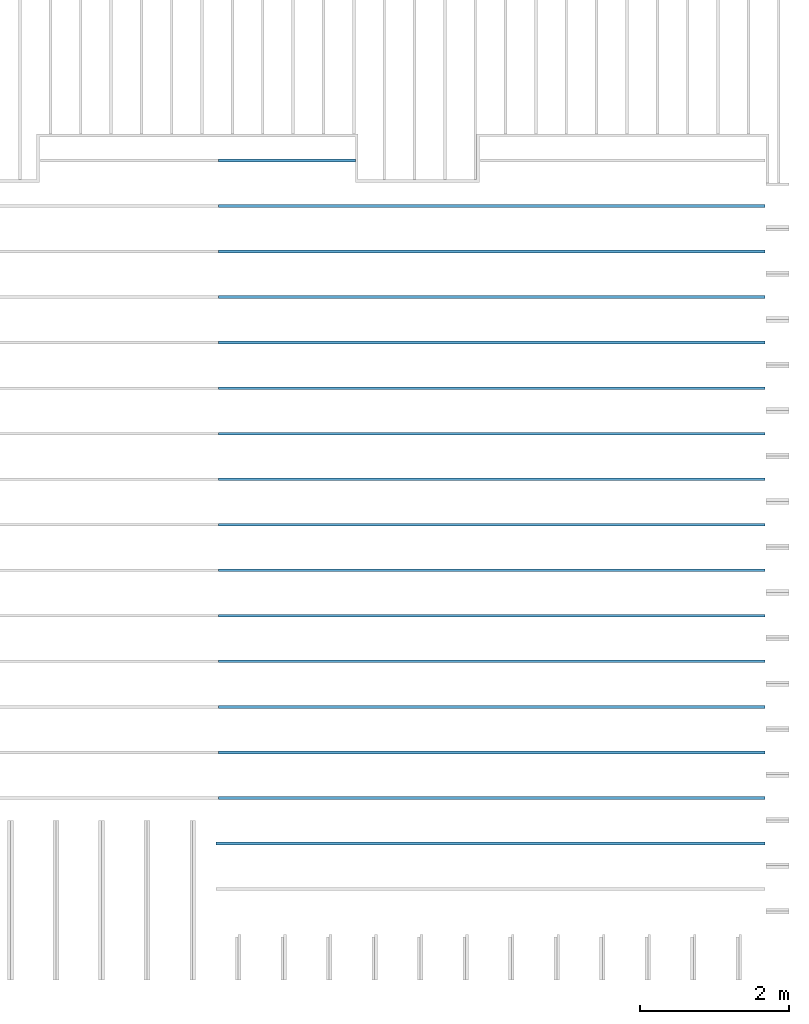
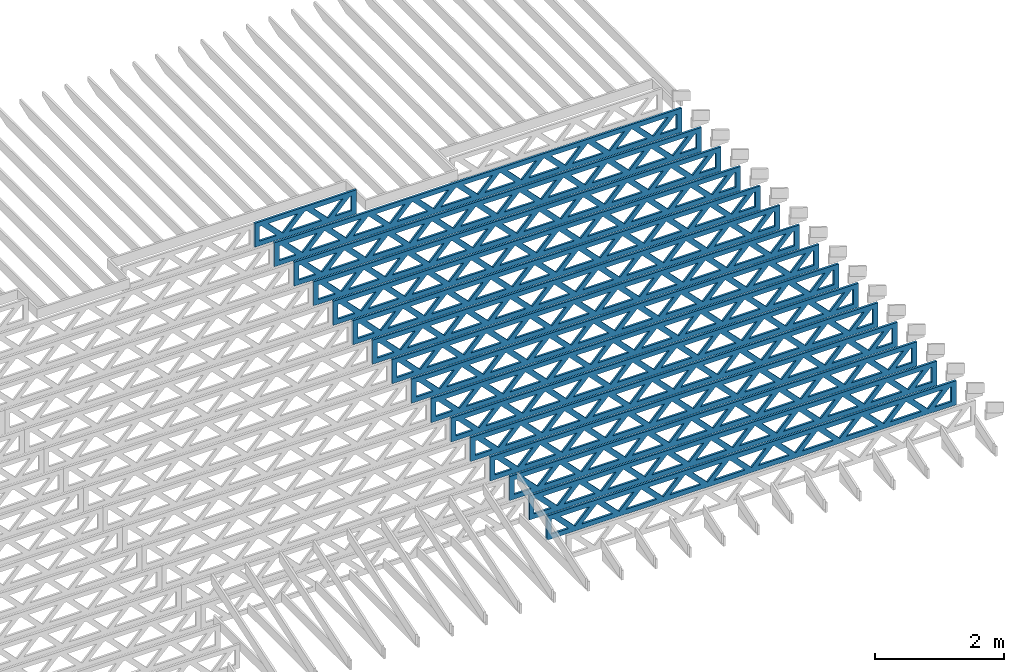
# One storey, part 12 of 18: 16 beams, 1 element without a shape of its own.
"""IFC4 building model written with IfcOpenShell, lengths in feet."""

from ifc_helpers import new_model, entity, si_unit, converted_unit, derived_unit, direction, frame, frame_2d, origin, origin_2d_with_axis, place, context, subcontext, project, spatial, rectangle, extrude, source, transform, mapped, material, material_profile, profile_set, profile_usage, type_object, type_shapes, element, aggregate, save


model = new_model("IFC4")

# Units and contexts
model_context_1 = context("Model", 3, precision=0.0001, world=origin(), true_north=direction((6.12303176911189e-17, 1.0)))
model_context_2 = context("Model", 3, precision=0.0001, world=origin(), true_north=direction((6.12303176911189e-17, 1.0)))
body_context = subcontext(model_context_2, "Body", "Model", "MODEL_VIEW")
ifc_project = project(units=[converted_unit("LENGTHUNIT", "FOOT", entity("IfcRatioMeasure", 0.3048), si_unit("LENGTHUNIT", "METRE"), dimensions=[1, 0, 0, 0, 0, 0, 0]), converted_unit("AREAUNIT", "SQUARE FOOT", entity("IfcRatioMeasure", 0.09290304), si_unit("AREAUNIT", "SQUARE_METRE"), dimensions=[2, 0, 0, 0, 0, 0, 0]), converted_unit("VOLUMEUNIT", "CUBIC FOOT", entity("IfcRatioMeasure", 0.028316846592), si_unit("VOLUMEUNIT", "CUBIC_METRE"), dimensions=[3, 0, 0, 0, 0, 0, 0]), converted_unit("PLANEANGLEUNIT", "DEGREE", entity("IfcRatioMeasure", 0.0174532925199433), si_unit("PLANEANGLEUNIT", "RADIAN"), dimensions=[0, 0, 0, 0, 0, 0, 0]), si_unit("MASSUNIT", "GRAM", prefix="KILO"), derived_unit("MASSDENSITYUNIT", [(si_unit("MASSUNIT", "GRAM", prefix="KILO"), 1), (si_unit("LENGTHUNIT", "METRE"), -3)]), derived_unit("MOMENTOFINERTIAUNIT", [(si_unit("LENGTHUNIT", "METRE"), 4)]), si_unit("TIMEUNIT", "SECOND"), si_unit("FREQUENCYUNIT", "HERTZ"), si_unit("THERMODYNAMICTEMPERATUREUNIT", "DEGREE_CELSIUS"), derived_unit("THERMALTRANSMITTANCEUNIT", [(si_unit("MASSUNIT", "GRAM", prefix="KILO"), 1), (si_unit("THERMODYNAMICTEMPERATUREUNIT", "KELVIN"), -1), (si_unit("TIMEUNIT", "SECOND"), -3)]), derived_unit("VOLUMETRICFLOWRATEUNIT", [(si_unit("LENGTHUNIT", "METRE"), 3), (si_unit("TIMEUNIT", "SECOND"), -1)]), si_unit("ELECTRICCURRENTUNIT", "AMPERE"), si_unit("ELECTRICVOLTAGEUNIT", "VOLT"), si_unit("POWERUNIT", "WATT"), si_unit("FORCEUNIT", "NEWTON"), si_unit("ILLUMINANCEUNIT", "LUX"), si_unit("LUMINOUSFLUXUNIT", "LUMEN"), si_unit("LUMINOUSINTENSITYUNIT", "CANDELA"), derived_unit("USERDEFINED", [(si_unit("MASSUNIT", "GRAM", prefix="KILO"), -1), (si_unit("LENGTHUNIT", "METRE"), -2), (si_unit("TIMEUNIT", "SECOND"), 3), (si_unit("LUMINOUSFLUXUNIT", "LUMEN"), 1)]), derived_unit("LINEARVELOCITYUNIT", [(si_unit("LENGTHUNIT", "METRE"), 1), (si_unit("TIMEUNIT", "SECOND"), -1)]), si_unit("PRESSUREUNIT", "PASCAL"), derived_unit("USERDEFINED", [(si_unit("LENGTHUNIT", "METRE"), -2), (si_unit("MASSUNIT", "GRAM", prefix="KILO"), 1), (si_unit("TIMEUNIT", "SECOND"), -2)]), derived_unit("LINEARFORCEUNIT", [(si_unit("MASSUNIT", "GRAM", prefix="KILO"), 1), (si_unit("LENGTHUNIT", "METRE"), 1), (si_unit("TIMEUNIT", "SECOND"), -2), (si_unit("LENGTHUNIT", "METRE"), -1)]), derived_unit("PLANARFORCEUNIT", [(si_unit("MASSUNIT", "GRAM", prefix="KILO"), 1), (si_unit("LENGTHUNIT", "METRE"), 1), (si_unit("TIMEUNIT", "SECOND"), -2), (si_unit("LENGTHUNIT", "METRE"), -2)])], contexts=[model_context_1])

# Site, building, storey
site_placement = place(None, origin())
site = spatial("IfcSite", under=ifc_project, at=site_placement, CompositionType="ELEMENT")
building_placement = place(site_placement, origin())
building = spatial("IfcBuilding", under=site, at=building_placement, CompositionType="ELEMENT")
storey_placement = place(building_placement, frame((0.0, 0.0, 30.4375000000082)))
storey = spatial("IfcBuildingStorey", under=building, at=storey_placement, Name="ROOF", CompositionType="ELEMENT", Elevation=30.4375000000082)

# Assembly, beams
assembly_placement = place(storey_placement, origin())
assembly = element("IfcElementAssembly", 1, at=assembly_placement, inside=storey, Name="Structural Beam System:Structural Framing System", ObjectType="Structural Beam System:Structural Framing System", AssemblyPlace="NOTDEFINED", PredefinedType="BEAM_GRID")
ifc_material = material(Name="WOOD TRUSS", Category="Materials")
ifc_material_profile_1 = material_profile(ifc_material, rectangle(XDim=1.73473973950632, YDim=0.125, at=origin_2d_with_axis()))
ifc_material_profile_2 = material_profile(ifc_material, rectangle(XDim=1.73473973950633, YDim=0.125, at=frame_2d((-1.11022302462516e-16, 0.0), x_axis=(1.0, 0.0))))
ifc_material_profile_3 = material_profile(ifc_material, rectangle(XDim=1.73473973950632, YDim=0.125, at=origin_2d_with_axis()))
ifc_material_profile_4 = material_profile(ifc_material, rectangle(XDim=1.73473973950633, YDim=0.125, at=origin_2d_with_axis()))
ifc_material_profile_5 = material_profile(ifc_material, rectangle(XDim=1.73473973950632, YDim=0.125, at=frame_2d((-5.55111512312578e-17, 0.0), x_axis=(1.0, 0.0))))
ifc_material_profile_6 = material_profile(ifc_material, rectangle(XDim=1.73473973950633, YDim=0.125, at=frame_2d((-2.77555756156289e-16, 0.0), x_axis=(1.0, 0.0))))
ifc_material_profile_7 = material_profile(ifc_material, rectangle(XDim=1.73473973950632, YDim=0.125, at=frame_2d((-4.9960036108132e-16, 0.0), x_axis=(1.0, 0.0))))
ifc_material_profile_8 = material_profile(ifc_material, rectangle(XDim=1.73473973950633, YDim=0.125, at=frame_2d((4.44089209850063e-16, 0.0), x_axis=(1.0, 0.0))))
ifc_material_profile_9 = material_profile(ifc_material, rectangle(XDim=1.73473973950632, YDim=0.125, at=origin_2d_with_axis()))
ifc_material_profile_10 = material_profile(ifc_material, rectangle(XDim=1.73473973950633, YDim=0.125, at=frame_2d((-4.9960036108132e-16, 0.0), x_axis=(1.0, 0.0))))
ifc_material_profile_11 = material_profile(ifc_material, rectangle(XDim=0.291666666666664, YDim=0.125, at=frame_2d((-2.77555756156289e-17, 0.0), x_axis=(1.0, 0.0))))
ifc_material_profile_12 = material_profile(ifc_material, rectangle(XDim=0.291666666666628, YDim=0.124999999999995, at=frame_2d((-5.55111512312578e-17, 0.0), x_axis=(1.0, 0.0))))
ifc_material_profile_13 = material_profile(ifc_material, rectangle(XDim=0.916666666666666, YDim=0.125000000000003, at=frame_2d((-2.77555756156289e-17, 0.0), x_axis=(1.0, 0.0))))
ifc_material_profile_14 = material_profile(ifc_material, rectangle(XDim=0.916666666666651, YDim=0.125, at=frame_2d((-2.77555756156289e-17, 0.0), x_axis=(1.0, 0.0))))
ifc_profile_set = profile_set([ifc_material_profile_1, ifc_material_profile_2, ifc_material_profile_3, ifc_material_profile_4, ifc_material_profile_5, ifc_material_profile_6, ifc_material_profile_7, ifc_material_profile_8, ifc_material_profile_9, ifc_material_profile_10, ifc_material_profile_11, ifc_material_profile_12, ifc_material_profile_13, ifc_material_profile_14])
ifc_profile_usage_1 = profile_usage(ifc_profile_set, cardinal=8)
beam_type_1 = type_object("IfcBeamType", PredefinedType="BEAM", material=ifc_profile_set)
shared_shape_1 = source(origin(), body_context, "Body", "SweptSolid", [
    extrude(rectangle(XDim=1.73473973950632, YDim=0.125, at=frame_2d((8.88178419700125e-16, 0.0), x_axis=(1.0, 0.0))), frame((8.31693784968716, 0.0, 0.101118361020562), z_axis=(0.720569184836762, 0.0, -0.693383046997606), x_axis=(0.693383046997606, 0.0, 0.720569184836762)), (0.0, 0.0, 1.0), 0.291666666666667),
    extrude(rectangle(XDim=1.73473973950633, YDim=0.125, at=frame_2d((4.9960036108132e-16, 0.0), x_axis=(1.0, 0.0))), frame((7.06665197601389, 0.0, -0.101118361020407), z_axis=(0.720569184836758, 0.0, 0.69338304699761), x_axis=(0.69338304699761, 0.0, -0.720569184836758)), (0.0, 0.0, 1.0), 0.291666666666667),
    extrude(rectangle(XDim=1.73473973950632, YDim=0.125, at=origin_2d_with_axis()), frame((5.71797854336309, 0.0, 0.101118361020562), z_axis=(0.720569184836762, 0.0, -0.693383046997606), x_axis=(0.693383046997606, 0.0, 0.720569184836762)), (0.0, 0.0, 1.0), 0.291666666666667),
    extrude(rectangle(XDim=1.73473973950633, YDim=0.125, at=frame_2d((-4.9960036108132e-16, 0.0), x_axis=(1.0, 0.0))), frame((4.46769266968982, 0.0, -0.101118361020407), z_axis=(0.720569184836758, 0.0, 0.69338304699761), x_axis=(0.69338304699761, 0.0, -0.720569184836758)), (0.0, 0.0, 1.0), 0.291666666666667),
    extrude(rectangle(XDim=1.73473973950632, YDim=0.125, at=frame_2d((3.33066907387547e-16, 0.0), x_axis=(1.0, 0.0))), frame((3.11901923703901, 0.0, 0.101118361020562), z_axis=(0.720569184836762, 0.0, -0.693383046997606), x_axis=(0.693383046997606, 0.0, 0.720569184836762)), (0.0, 0.0, 1.0), 0.291666666666667),
    extrude(rectangle(XDim=1.73473973950633, YDim=0.125, at=frame_2d((-1.11022302462516e-16, 0.0), x_axis=(1.0, 0.0))), frame((1.86873336336574, 0.0, -0.101118361020407), z_axis=(0.720569184836758, 0.0, 0.69338304699761), x_axis=(0.69338304699761, 0.0, -0.720569184836758)), (0.0, 0.0, 1.0), 0.291666666666666),
    extrude(rectangle(XDim=1.73473973950632, YDim=0.125, at=frame_2d((5.55111512312578e-17, 0.0), x_axis=(1.0, 0.0))), frame((0.520059930714937, 0.0, 0.101118361020562), z_axis=(0.720569184836762, 0.0, -0.693383046997606), x_axis=(0.693383046997606, 0.0, 0.720569184836762)), (0.0, 0.0, 1.0), 0.291666666666667),
    extrude(rectangle(XDim=1.73473973950633, YDim=0.125, at=origin_2d_with_axis()), frame((-0.730225942958334, 0.0, -0.101118361020407), z_axis=(0.720569184836758, 0.0, 0.69338304699761), x_axis=(0.69338304699761, 0.0, -0.720569184836758)), (0.0, 0.0, 1.0), 0.291666666666666),
    extrude(rectangle(XDim=1.73473973950632, YDim=0.125, at=frame_2d((-5.55111512312578e-17, 0.0), x_axis=(1.0, 0.0))), frame((-2.07889937560914, 0.0, 0.101118361020562), z_axis=(0.720569184836762, 0.0, -0.693383046997606), x_axis=(0.693383046997606, 0.0, 0.720569184836762)), (0.0, 0.0, 1.0), 0.291666666666667),
    extrude(rectangle(XDim=1.73473973950633, YDim=0.125, at=frame_2d((-2.77555756156289e-16, 0.0), x_axis=(1.0, 0.0))), frame((-3.32918524928241, 0.0, -0.101118361020407), z_axis=(0.720569184836758, 0.0, 0.69338304699761), x_axis=(0.69338304699761, 0.0, -0.720569184836758)), (0.0, 0.0, 1.0), 0.291666666666666),
    extrude(rectangle(XDim=1.73473973950632, YDim=0.125, at=origin_2d_with_axis()), frame((-4.67785868193321, 0.0, 0.101118361020562), z_axis=(0.720569184836762, 0.0, -0.693383046997606), x_axis=(0.693383046997606, 0.0, 0.720569184836762)), (0.0, 0.0, 1.0), 0.291666666666667),
    extrude(rectangle(XDim=1.73473973950633, YDim=0.125, at=frame_2d((-4.9960036108132e-16, 0.0), x_axis=(1.0, 0.0))), frame((-5.92814455560648, 0.0, -0.101118361020407), z_axis=(0.720569184836758, 0.0, 0.69338304699761), x_axis=(0.69338304699761, 0.0, -0.720569184836758)), (0.0, 0.0, 1.0), 0.291666666666667),
    extrude(rectangle(XDim=1.73473973950632, YDim=0.125, at=frame_2d((-5.55111512312578e-16, 0.0), x_axis=(1.0, 0.0))), frame((-7.27681798825729, 0.0, 0.101118361020562), z_axis=(0.720569184836762, 0.0, -0.693383046997606), x_axis=(0.693383046997606, 0.0, 0.720569184836762)), (0.0, 0.0, 1.0), 0.291666666666667),
    extrude(rectangle(XDim=1.73473973950633, YDim=0.125, at=origin_2d_with_axis()), frame((-8.52710386193056, 0.0, -0.101118361020407), z_axis=(0.720569184836758, 0.0, 0.69338304699761), x_axis=(0.69338304699761, 0.0, -0.720569184836758)), (0.0, 0.0, 1.0), 0.291666666666666),
    extrude(rectangle(XDim=1.73473973950632, YDim=0.125, at=frame_2d((-1.0547118733939e-15, 0.0), x_axis=(1.0, 0.0))), frame((10.9158971560112, 0.0, 0.101118361020503), z_axis=(0.720569184836762, 0.0, -0.693383046997606), x_axis=(0.693383046997606, 0.0, 0.720569184836762)), (0.0, 0.0, 1.0), 0.291666666666664),
    extrude(rectangle(XDim=1.73473973950633, YDim=0.125, at=origin_2d_with_axis()), frame((9.66561128233796, 0.0, -0.101118361020466), z_axis=(0.720569184836758, 0.0, 0.69338304699761), x_axis=(0.69338304699761, 0.0, -0.720569184836758)), (0.0, 0.0, 1.0), 0.291666666666666),
    extrude(rectangle(XDim=1.73473973950632, YDim=0.125, at=frame_2d((9.43689570931383e-16, 0.0), x_axis=(1.0, 0.0))), frame((-9.87577729458136, 0.0, 0.101118361020564), z_axis=(0.720569184836762, 0.0, -0.693383046997606), x_axis=(0.693383046997606, 0.0, 0.720569184836762)), (0.0, 0.0, 1.0), 0.291666666666667),
    extrude(rectangle(XDim=1.73473973950633, YDim=0.125, at=origin_2d_with_axis()), frame((-11.1260631682546, 0.0, -0.101118361020405), z_axis=(0.720569184836758, 0.0, 0.69338304699761), x_axis=(0.69338304699761, 0.0, -0.720569184836758)), (0.0, 0.0, 1.0), 0.291666666666666),
    extrude(rectangle(XDim=0.291666666666664, YDim=0.125, at=frame_2d((-2.77555756156289e-17, 0.0), x_axis=(1.0, 0.0))), frame((-12.0625038919629, 0.0, 0.604166666666611), z_axis=(1.0, 0.0, 0.0), x_axis=(0.0, 0.0, -1.0)), (0.0, 0.0, 1.0), 24.1250077839258),
    extrude(rectangle(XDim=0.291666666666628, YDim=0.124999999999995, at=frame_2d((-5.55111512312578e-17, 0.0), x_axis=(1.0, 0.0))), frame((-12.0625038919627, 0.0, -0.604166666666693), z_axis=(1.0, 0.0, 0.0), x_axis=(0.0, 0.0, -1.0)), (0.0, 0.0, 1.0), 24.1250077839255),
    extrude(rectangle(XDim=0.916666666666666, YDim=0.125000000000003, at=frame_2d((-2.77555756156289e-17, 0.0), x_axis=(1.0, 0.0))), frame((11.7708372252962, 0.0, 0.0), z_axis=(1.0, 0.0, 0.0), x_axis=(0.0, 0.0, -1.0)), (0.0, 0.0, 1.0), 0.291666666666687),
    extrude(rectangle(XDim=0.916666666666651, YDim=0.125, at=frame_2d((-2.77555756156289e-17, -6.93889390390723e-18), x_axis=(1.0, 0.0))), frame((-12.0625038919629, 0.0, 0.0), z_axis=(1.0, 0.0, 0.0), x_axis=(0.0, 0.0, -1.0)), (0.0, 0.0, 1.0), 0.291666666666687),
])
type_shapes(beam_type_1, [shared_shape_1])
beam_1_placement = place(assembly_placement, frame((-152.4673232603, 927.861934882651, 0.749999999991697), z_axis=(0.0, 0.0, 1.0), x_axis=(-1.0, 0.0, 0.0)))
beam_1 = element("IfcBeam", 2, at=beam_1_placement, type_object=beam_type_1, material=ifc_profile_usage_1, PredefinedType="BEAM", context=body_context, shape_type="MappedRepresentation", body=[
    mapped(shared_shape_1, transform((0.0, 0.0, 0.0), scale=1.0)),
])
ifc_profile_usage_2 = profile_usage(ifc_profile_set, cardinal=8)
beam_type_2 = type_object("IfcBeamType", PredefinedType="BEAM", material=ifc_profile_set)
shared_shape_2 = source(origin(), body_context, "Body", "SweptSolid", [
    extrude(rectangle(XDim=1.73473973950632, YDim=0.125, at=frame_2d((8.88178419700125e-16, 0.0), x_axis=(1.0, 0.0))), frame((8.27006284966195, 0.0, 0.101118361020562), z_axis=(0.720569184836762, 0.0, -0.693383046997606), x_axis=(0.693383046997606, 0.0, 0.720569184836762)), (0.0, 0.0, 1.0), 0.291666666666667),
    extrude(rectangle(XDim=1.73473973950633, YDim=0.125, at=frame_2d((4.9960036108132e-16, 0.0), x_axis=(1.0, 0.0))), frame((7.01977697598868, 0.0, -0.101118361020407), z_axis=(0.720569184836758, 0.0, 0.69338304699761), x_axis=(0.69338304699761, 0.0, -0.720569184836758)), (0.0, 0.0, 1.0), 0.291666666666667),
    extrude(rectangle(XDim=1.73473973950632, YDim=0.125, at=origin_2d_with_axis()), frame((5.68672854334628, 0.0, 0.101118361020562), z_axis=(0.720569184836762, 0.0, -0.693383046997606), x_axis=(0.693383046997606, 0.0, 0.720569184836762)), (0.0, 0.0, 1.0), 0.291666666666667),
    extrude(rectangle(XDim=1.73473973950633, YDim=0.125, at=frame_2d((-4.9960036108132e-16, 0.0), x_axis=(1.0, 0.0))), frame((4.43644266967301, 0.0, -0.101118361020407), z_axis=(0.720569184836758, 0.0, 0.69338304699761), x_axis=(0.69338304699761, 0.0, -0.720569184836758)), (0.0, 0.0, 1.0), 0.291666666666667),
    extrude(rectangle(XDim=1.73473973950632, YDim=0.125, at=frame_2d((3.33066907387547e-16, 0.0), x_axis=(1.0, 0.0))), frame((3.10339423703061, 0.0, 0.101118361020562), z_axis=(0.720569184836762, 0.0, -0.693383046997606), x_axis=(0.693383046997606, 0.0, 0.720569184836762)), (0.0, 0.0, 1.0), 0.291666666666667),
    extrude(rectangle(XDim=1.73473973950633, YDim=0.125, at=frame_2d((-1.11022302462516e-16, 0.0), x_axis=(1.0, 0.0))), frame((1.85310836335734, 0.0, -0.101118361020407), z_axis=(0.720569184836758, 0.0, 0.69338304699761), x_axis=(0.69338304699761, 0.0, -0.720569184836758)), (0.0, 0.0, 1.0), 0.291666666666666),
    extrude(rectangle(XDim=1.73473973950632, YDim=0.125, at=frame_2d((5.55111512312578e-17, 0.0), x_axis=(1.0, 0.0))), frame((0.520059930714937, 0.0, 0.101118361020562), z_axis=(0.720569184836762, 0.0, -0.693383046997606), x_axis=(0.693383046997606, 0.0, 0.720569184836762)), (0.0, 0.0, 1.0), 0.291666666666667),
    extrude(rectangle(XDim=1.73473973950633, YDim=0.125, at=origin_2d_with_axis()), frame((-0.730225942958334, 0.0, -0.101118361020407), z_axis=(0.720569184836758, 0.0, 0.69338304699761), x_axis=(0.69338304699761, 0.0, -0.720569184836758)), (0.0, 0.0, 1.0), 0.291666666666666),
    extrude(rectangle(XDim=1.73473973950632, YDim=0.125, at=frame_2d((-5.55111512312578e-17, 0.0), x_axis=(1.0, 0.0))), frame((-2.06327437560074, 0.0, 0.101118361020562), z_axis=(0.720569184836762, 0.0, -0.693383046997606), x_axis=(0.693383046997606, 0.0, 0.720569184836762)), (0.0, 0.0, 1.0), 0.291666666666667),
    extrude(rectangle(XDim=1.73473973950633, YDim=0.125, at=frame_2d((-2.77555756156289e-16, 0.0), x_axis=(1.0, 0.0))), frame((-3.31356024927401, 0.0, -0.101118361020407), z_axis=(0.720569184836758, 0.0, 0.69338304699761), x_axis=(0.69338304699761, 0.0, -0.720569184836758)), (0.0, 0.0, 1.0), 0.291666666666666),
    extrude(rectangle(XDim=1.73473973950632, YDim=0.125, at=origin_2d_with_axis()), frame((-4.64660868191641, 0.0, 0.101118361020562), z_axis=(0.720569184836762, 0.0, -0.693383046997606), x_axis=(0.693383046997606, 0.0, 0.720569184836762)), (0.0, 0.0, 1.0), 0.291666666666667),
    extrude(rectangle(XDim=1.73473973950633, YDim=0.125, at=frame_2d((-4.9960036108132e-16, 0.0), x_axis=(1.0, 0.0))), frame((-5.89689455558968, 0.0, -0.101118361020407), z_axis=(0.720569184836758, 0.0, 0.69338304699761), x_axis=(0.69338304699761, 0.0, -0.720569184836758)), (0.0, 0.0, 1.0), 0.291666666666667),
    extrude(rectangle(XDim=1.73473973950632, YDim=0.125, at=frame_2d((5.55111512312578e-16, 0.0), x_axis=(1.0, 0.0))), frame((-7.22994298823208, 0.0, 0.101118361020562), z_axis=(0.720569184836762, 0.0, -0.693383046997606), x_axis=(0.693383046997606, 0.0, 0.720569184836762)), (0.0, 0.0, 1.0), 0.291666666666667),
    extrude(rectangle(XDim=1.73473973950633, YDim=0.125, at=origin_2d_with_axis()), frame((-8.48022886190535, 0.0, -0.101118361020407), z_axis=(0.720569184836758, 0.0, 0.69338304699761), x_axis=(0.69338304699761, 0.0, -0.720569184836758)), (0.0, 0.0, 1.0), 0.291666666666666),
    extrude(rectangle(XDim=1.73473973950632, YDim=0.125, at=frame_2d((-8.88178419700125e-16, 0.0), x_axis=(1.0, 0.0))), frame((10.8533971559776, 0.0, 0.101118361020503), z_axis=(0.720569184836762, 0.0, -0.693383046997606), x_axis=(0.693383046997606, 0.0, 0.720569184836762)), (0.0, 0.0, 1.0), 0.291666666666664),
    extrude(rectangle(XDim=1.73473973950633, YDim=0.125, at=origin_2d_with_axis()), frame((9.60311128230435, 0.0, -0.101118361020466), z_axis=(0.720569184836758, 0.0, 0.69338304699761), x_axis=(0.69338304699761, 0.0, -0.720569184836758)), (0.0, 0.0, 1.0), 0.291666666666666),
    extrude(rectangle(XDim=1.73473973950632, YDim=0.125, at=frame_2d((8.88178419700125e-16, 0.0), x_axis=(1.0, 0.0))), frame((-9.81327729454775, 0.0, 0.101118361020564), z_axis=(0.720569184836762, 0.0, -0.693383046997606), x_axis=(0.693383046997606, 0.0, 0.720569184836762)), (0.0, 0.0, 1.0), 0.291666666666667),
    extrude(rectangle(XDim=1.73473973950633, YDim=0.125, at=origin_2d_with_axis()), frame((-11.063563168221, 0.0, -0.101118361020405), z_axis=(0.720569184836758, 0.0, 0.69338304699761), x_axis=(0.69338304699761, 0.0, -0.720569184836758)), (0.0, 0.0, 1.0), 0.291666666666666),
    extrude(rectangle(XDim=0.291666666666664, YDim=0.125, at=frame_2d((-2.77555756156289e-17, 0.0), x_axis=(1.0, 0.0))), frame((-12.0000038919293, 0.0, 0.604166666666611), z_axis=(1.0, 0.0, 0.0), x_axis=(0.0, 0.0, -1.0)), (0.0, 0.0, 1.0), 24.0000077838585),
    extrude(rectangle(XDim=0.291666666666628, YDim=0.124999999999995, at=frame_2d((-5.55111512312578e-17, 0.0), x_axis=(1.0, 0.0))), frame((-12.0000038919291, 0.0, -0.604166666666693), z_axis=(1.0, 0.0, 0.0), x_axis=(0.0, 0.0, -1.0)), (0.0, 0.0, 1.0), 24.0000077838583),
    extrude(rectangle(XDim=0.916666666666666, YDim=0.125000000000003, at=frame_2d((-2.77555756156289e-17, 0.0), x_axis=(1.0, 0.0))), frame((11.7083372252626, 0.0, 0.0), z_axis=(1.0, 0.0, 0.0), x_axis=(0.0, 0.0, -1.0)), (0.0, 0.0, 1.0), 0.291666666666687),
    extrude(rectangle(XDim=0.916666666666651, YDim=0.125, at=frame_2d((-2.77555756156289e-17, 0.0), x_axis=(1.0, 0.0))), frame((-12.0000038919293, 0.0, 0.0), z_axis=(1.0, 0.0, 0.0), x_axis=(0.0, 0.0, -1.0)), (0.0, 0.0, 1.0), 0.291666666666687),
])
type_shapes(beam_type_2, [shared_shape_2])
beam_2_placement = place(assembly_placement, frame((-152.404823260266, 931.861934882651, 0.749999999991687), z_axis=(0.0, 0.0, 1.0), x_axis=(-1.0, 0.0, 0.0)))
beam_2 = element("IfcBeam", 3, at=beam_2_placement, type_object=beam_type_2, material=ifc_profile_usage_2, PredefinedType="BEAM", context=body_context, shape_type="MappedRepresentation", body=[
    mapped(shared_shape_2, transform((0.0, 0.0, 0.0), scale=1.0)),
])
ifc_profile_usage_3 = profile_usage(ifc_profile_set, cardinal=8)
beam_3_placement = place(assembly_placement, frame((-152.404823260266, 933.861934882651, 0.74999999999168), z_axis=(0.0, 0.0, 1.0), x_axis=(-1.0, 0.0, 0.0)))
beam_3 = element("IfcBeam", 4, at=beam_3_placement, type_object=beam_type_2, material=ifc_profile_usage_3, PredefinedType="BEAM", context=body_context, shape_type="MappedRepresentation", body=[
    mapped(shared_shape_2, transform((0.0, 0.0, 0.0), scale=1.0)),
])
ifc_profile_usage_4 = profile_usage(ifc_profile_set, cardinal=8)
beam_4_placement = place(assembly_placement, frame((-152.404823260266, 935.861934882651, 0.749999999991672), z_axis=(0.0, 0.0, 1.0), x_axis=(-1.0, 0.0, 0.0)))
beam_4 = element("IfcBeam", 5, at=beam_4_placement, type_object=beam_type_2, material=ifc_profile_usage_4, PredefinedType="BEAM", context=body_context, shape_type="MappedRepresentation", body=[
    mapped(shared_shape_2, transform((0.0, 0.0, 0.0), scale=1.0)),
])
ifc_profile_usage_5 = profile_usage(ifc_profile_set, cardinal=8)
beam_5_placement = place(assembly_placement, frame((-152.404823260266, 937.861934882651, 0.749999999991669), z_axis=(0.0, 0.0, 1.0), x_axis=(-1.0, 0.0, 0.0)))
beam_5 = element("IfcBeam", 6, at=beam_5_placement, type_object=beam_type_2, material=ifc_profile_usage_5, PredefinedType="BEAM", context=body_context, shape_type="MappedRepresentation", body=[
    mapped(shared_shape_2, transform((0.0, 0.0, 0.0), scale=1.0)),
])
ifc_profile_usage_6 = profile_usage(ifc_profile_set, cardinal=8)
beam_6_placement = place(assembly_placement, frame((-152.404823260266, 945.861934882651, 0.749999999991648), z_axis=(0.0, 0.0, 1.0), x_axis=(-1.0, 0.0, 0.0)))
beam_6 = element("IfcBeam", 7, at=beam_6_placement, type_object=beam_type_2, material=ifc_profile_usage_6, PredefinedType="BEAM", context=body_context, shape_type="MappedRepresentation", body=[
    mapped(shared_shape_2, transform((0.0, 0.0, 0.0), scale=1.0)),
])
ifc_profile_usage_7 = profile_usage(ifc_profile_set, cardinal=8)
beam_7_placement = place(assembly_placement, frame((-152.404823260266, 947.861934882651, 0.74999999999164), z_axis=(0.0, 0.0, 1.0), x_axis=(-1.0, 0.0, 0.0)))
beam_7 = element("IfcBeam", 8, at=beam_7_placement, type_object=beam_type_2, material=ifc_profile_usage_7, PredefinedType="BEAM", context=body_context, shape_type="MappedRepresentation", body=[
    mapped(shared_shape_2, transform((0.0, 0.0, 0.0), scale=1.0)),
])
ifc_profile_usage_8 = profile_usage(ifc_profile_set, cardinal=8)
beam_8_placement = place(assembly_placement, frame((-152.404823260266, 939.861934882651, 0.749999999991662), z_axis=(0.0, 0.0, 1.0), x_axis=(-1.0, 0.0, 0.0)))
beam_8 = element("IfcBeam", 9, at=beam_8_placement, type_object=beam_type_2, material=ifc_profile_usage_8, PredefinedType="BEAM", context=body_context, shape_type="MappedRepresentation", body=[
    mapped(shared_shape_2, transform((0.0, 0.0, 0.0), scale=1.0)),
])
ifc_profile_usage_9 = profile_usage(ifc_profile_set, cardinal=8)
beam_9_placement = place(assembly_placement, frame((-152.404823260266, 941.861934882651, 0.749999999991658), z_axis=(0.0, 0.0, 1.0), x_axis=(-1.0, 0.0, 0.0)))
beam_9 = element("IfcBeam", 10, at=beam_9_placement, type_object=beam_type_2, material=ifc_profile_usage_9, PredefinedType="BEAM", context=body_context, shape_type="MappedRepresentation", body=[
    mapped(shared_shape_2, transform((0.0, 0.0, 0.0), scale=1.0)),
])
ifc_profile_usage_10 = profile_usage(ifc_profile_set, cardinal=8)
beam_10_placement = place(assembly_placement, frame((-152.404823260266, 943.861934882651, 0.749999999991651), z_axis=(0.0, 0.0, 1.0), x_axis=(-1.0, 0.0, 0.0)))
beam_10 = element("IfcBeam", 11, at=beam_10_placement, type_object=beam_type_2, material=ifc_profile_usage_10, PredefinedType="BEAM", context=body_context, shape_type="MappedRepresentation", body=[
    mapped(shared_shape_2, transform((0.0, 0.0, 0.0), scale=1.0)),
])
ifc_profile_usage_11 = profile_usage(ifc_profile_set, cardinal=8)
beam_11_placement = place(assembly_placement, frame((-152.404823260266, 949.861934882651, 0.749999999991633), z_axis=(0.0, 0.0, 1.0), x_axis=(-1.0, 0.0, 0.0)))
beam_11 = element("IfcBeam", 12, at=beam_11_placement, type_object=beam_type_2, material=ifc_profile_usage_11, PredefinedType="BEAM", context=body_context, shape_type="MappedRepresentation", body=[
    mapped(shared_shape_2, transform((0.0, 0.0, 0.0), scale=1.0)),
])
ifc_profile_usage_12 = profile_usage(ifc_profile_set, cardinal=8)
beam_12_placement = place(assembly_placement, frame((-152.404823260266, 953.861934882651, 0.749999999991623), z_axis=(0.0, 0.0, 1.0), x_axis=(-1.0, 0.0, 0.0)))
beam_12 = element("IfcBeam", 13, at=beam_12_placement, type_object=beam_type_2, material=ifc_profile_usage_12, PredefinedType="BEAM", context=body_context, shape_type="MappedRepresentation", body=[
    mapped(shared_shape_2, transform((0.0, 0.0, 0.0), scale=1.0)),
])
ifc_profile_usage_13 = profile_usage(ifc_profile_set, cardinal=8)
beam_13_placement = place(assembly_placement, frame((-152.404823260266, 955.861934882651, 0.749999999991619), z_axis=(0.0, 0.0, 1.0), x_axis=(-1.0, 0.0, 0.0)))
beam_13 = element("IfcBeam", 14, at=beam_13_placement, type_object=beam_type_2, material=ifc_profile_usage_13, PredefinedType="BEAM", context=body_context, shape_type="MappedRepresentation", body=[
    mapped(shared_shape_2, transform((0.0, 0.0, 0.0), scale=1.0)),
])
ifc_profile_usage_14 = profile_usage(ifc_profile_set, cardinal=8)
beam_14_placement = place(assembly_placement, frame((-152.404823260266, 951.861934882651, 0.74999999999163), z_axis=(0.0, 0.0, 1.0), x_axis=(-1.0, 0.0, 0.0)))
beam_14 = element("IfcBeam", 15, at=beam_14_placement, type_object=beam_type_2, material=ifc_profile_usage_14, PredefinedType="BEAM", context=body_context, shape_type="MappedRepresentation", body=[
    mapped(shared_shape_2, transform((0.0, 0.0, 0.0), scale=1.0)),
])
ifc_profile_usage_15 = profile_usage(ifc_profile_set, cardinal=8)
beam_15_placement = place(assembly_placement, frame((-152.404823260266, 929.861934882651, 0.74999999999169), z_axis=(0.0, 0.0, 1.0), x_axis=(-1.0, 0.0, 0.0)))
beam_15 = element("IfcBeam", 16, at=beam_15_placement, type_object=beam_type_2, material=ifc_profile_usage_15, PredefinedType="BEAM", context=body_context, shape_type="MappedRepresentation", body=[
    mapped(shared_shape_2, transform((0.0, 0.0, 0.0), scale=1.0)),
])
ifc_profile_usage_16 = profile_usage(ifc_profile_set, cardinal=8)
beam_type_3 = type_object("IfcBeamType", PredefinedType="BEAM", material=ifc_profile_set)
shared_shape_3 = source(origin(), body_context, "Body", "SweptSolid", [
    extrude(rectangle(XDim=1.73473973950632, YDim=0.125, at=frame_2d((5.55111512312578e-17, 0.0), x_axis=(1.0, 0.0))), frame((1.853392761574, 0.0, 0.101118361020515), z_axis=(0.720569184836762, 0.0, -0.693383046997606), x_axis=(0.693383046997606, 0.0, 0.720569184836762)), (0.0, 0.0, 1.0), 0.291666666666667),
    extrude(rectangle(XDim=1.73473973950633, YDim=0.125, at=frame_2d((-1.11022302462516e-16, 0.0), x_axis=(1.0, 0.0))), frame((0.603106887900734, 0.0, -0.101118361020454), z_axis=(0.720569184836758, 0.0, 0.69338304699761), x_axis=(0.69338304699761, 0.0, -0.720569184836758)), (0.0, 0.0, 1.0), 0.291666666666667),
    extrude(rectangle(XDim=1.73473973950632, YDim=0.125, at=frame_2d((-5.55111512312578e-17, 0.0), x_axis=(1.0, 0.0))), frame((-0.813272900144133, 0.0, 0.101118361020554), z_axis=(0.720569184836762, 0.0, -0.693383046997606), x_axis=(0.693383046997606, 0.0, 0.720569184836762)), (0.0, 0.0, 1.0), 0.291666666666667),
    extrude(rectangle(XDim=1.73473973950633, YDim=0.125, at=frame_2d((-1.66533453693773e-16, 0.0), x_axis=(1.0, 0.0))), frame((-2.0635587738174, 0.0, -0.101118361020415), z_axis=(0.720569184836758, 0.0, 0.69338304699761), x_axis=(0.69338304699761, 0.0, -0.720569184836758)), (0.0, 0.0, 1.0), 0.291666666666666),
    extrude(rectangle(XDim=0.291666666666664, YDim=0.125, at=frame_2d((-2.77555756156289e-17, 0.0), x_axis=(1.0, 0.0))), frame((-2.99999949752565, 0.0, 0.604166666666611), z_axis=(1.0, 0.0, 0.0), x_axis=(0.0, 0.0, -1.0)), (0.0, 0.0, 1.0), 5.9999989950513),
    extrude(rectangle(XDim=0.291666666666628, YDim=0.124999999999995, at=frame_2d((-5.55111512312578e-17, 0.0), x_axis=(1.0, 0.0))), frame((-2.99999949752544, 0.0, -0.604166666666693), z_axis=(1.0, 0.0, 0.0), x_axis=(0.0, 0.0, -1.0)), (0.0, 0.0, 1.0), 5.99999899505109),
    extrude(rectangle(XDim=0.916666666666666, YDim=0.125000000000003, at=frame_2d((-2.77555756156289e-17, 0.0), x_axis=(1.0, 0.0))), frame((2.70833283085896, 0.0, 0.0), z_axis=(1.0, 0.0, 0.0), x_axis=(0.0, 0.0, -1.0)), (0.0, 0.0, 1.0), 0.291666666666687),
    extrude(rectangle(XDim=0.916666666666651, YDim=0.125, at=frame_2d((-2.77555756156289e-17, 0.0), x_axis=(1.0, 0.0))), frame((-2.99999949752565, 0.0, 0.0), z_axis=(1.0, 0.0, 0.0), x_axis=(0.0, 0.0, -1.0)), (0.0, 0.0, 1.0), 0.291666666666687),
])
type_shapes(beam_type_3, [shared_shape_3])
beam_16_placement = place(assembly_placement, frame((-161.40482765467, 957.861934882651, 0.749999999991616), z_axis=(0.0, 0.0, 1.0), x_axis=(-1.0, 0.0, 0.0)))
beam_16 = element("IfcBeam", 17, at=beam_16_placement, type_object=beam_type_3, material=ifc_profile_usage_16, PredefinedType="BEAM", context=body_context, shape_type="MappedRepresentation", body=[
    mapped(shared_shape_3, transform((0.0, 0.0, 0.0), scale=1.0)),
])
aggregate(assembly, [beam_2, beam_3, beam_4, beam_5, beam_6, beam_7, beam_16, beam_1, beam_8, beam_9, beam_10, beam_11, beam_12, beam_13, beam_14, beam_15])

save(model, "model.ifc")
